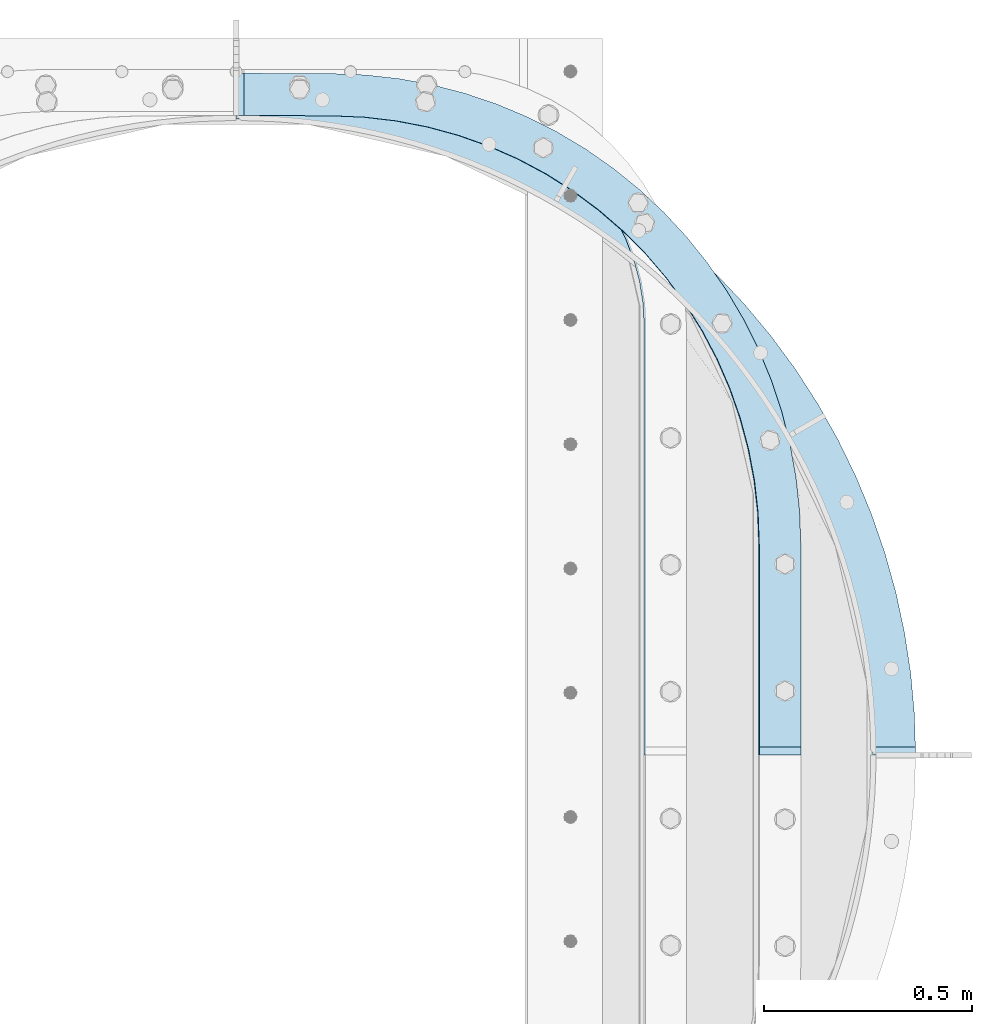
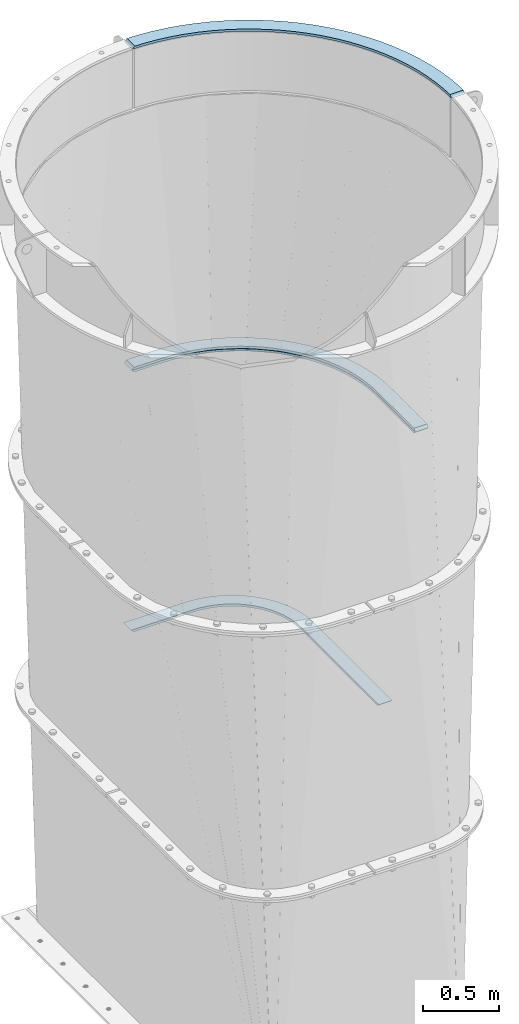
# One storey, part 14 of 15: 4 plates, 3 elements without a shape of their own.
"""IFC2X3 building model written with IfcOpenShell, lengths in millimetres."""

from ifc_helpers import new_model, si_unit, frame, origin_with_axes, place, context, subcontext, project, spatial, faceted_brep, material, type_object, element, aggregate, save


model = new_model("IFC2X3")

# Units and contexts
model_context = context("Model", 3, precision=1e-05, world=origin_with_axes())
body_context = subcontext(model_context, "Body", "Model", "MODEL_VIEW")
ifc_project = project(units=[si_unit("LENGTHUNIT", "METRE", prefix="MILLI"), si_unit("AREAUNIT", "SQUARE_METRE"), si_unit("VOLUMEUNIT", "CUBIC_METRE"), si_unit("MASSUNIT", "GRAM", prefix="KILO"), si_unit("TIMEUNIT", "SECOND"), si_unit("PLANEANGLEUNIT", "RADIAN"), si_unit("SOLIDANGLEUNIT", "STERADIAN"), si_unit("THERMODYNAMICTEMPERATUREUNIT", "DEGREE_CELSIUS"), si_unit("LUMINOUSINTENSITYUNIT", "LUMEN")], contexts=[model_context])

# Site, building, storey
site_placement = place(None, origin_with_axes())
site = spatial("IfcSite", under=ifc_project, at=site_placement, CompositionType="ELEMENT")
building_placement = place(site_placement, origin_with_axes())
building = spatial("IfcBuilding", under=site, at=building_placement, Name="Undefined", CompositionType="ELEMENT")
storey_placement = place(building_placement, origin_with_axes())
storey = spatial("IfcBuildingStorey", under=building, at=storey_placement, Name="Undefined", CompositionType="ELEMENT", Elevation=0.0)

# Assembly, plate
assembly_1_placement = place(storey_placement, origin_with_axes())
assembly_1 = element("IfcElementAssembly", 1, at=assembly_1_placement, inside=storey, Name="TRANSITION", AssemblyPlace="NOTDEFINED", PredefinedType="RIGID_FRAME")
ifc_material = material(Name="STEEL/A36")
plate_type_1 = type_object("IfcPlateType", PredefinedType="NOTDEFINED")
plate_1_placement = place(assembly_1_placement, frame((2235.57307813265, 1720.87907416661, 4192.06000019074), z_axis=(0.0, 1.0, 0.0), x_axis=(-1.0, 0.0, 0.0)))
plate_1 = element("IfcPlate", 2, at=plate_1_placement, type_object=plate_type_1, material=ifc_material, Name="PLATE", context=body_context, shape_type="Brep", body=[
    faceted_brep([(99.7946651598986, 9.52499949498906, 19.0499993169162), (99.7946014404297, -9.52499999999964, 0.0), (0.0, -9.52499999999964, 0.0), (8.52415855661093e-05, 9.52499999999964, 19.050446296787), (0.00226665040457874, -9.52499999999964, 506.568496906642), (2.86552112687696, -9.52499999999964, 586.965399212112), (2.86552112687696, 9.52499999999964, 586.965399212112), (0.00226665040457874, 9.52499999999964, 506.568496906642), (11.4400606208065, -9.52499999999964, 666.955007280796), (11.4400606208065, 9.52499999999964, 666.955007280796), (25.682448871113, -9.52499999999964, 746.132115736726), (25.682448871113, 9.52499999999964, 746.132115736726), (45.5205378522613, -9.52499999999964, 824.095635103739), (45.5205378522613, 9.52499999999964, 824.095635103739), (70.8538332563299, -9.52499999999964, 900.450623614542), (70.8538332563299, 9.52499999999964, 900.450623614542), (101.554003569561, -9.52499999999964, 974.810287877187), (101.554003569561, 9.52499999999964, 974.810287877187), (137.465530164548, -9.52499999999964, 1046.79794226412), (137.465530164548, 9.52499999999964, 1046.79794226412), (178.406495114871, -9.52499999999964, 1116.04891709806), (178.406495114871, 9.52499999999964, 1116.04891709806), (224.169502741328, -9.52499999999964, 1182.2124059684), (224.169502741328, 9.52499999999964, 1182.2124059684), (274.522730221457, -9.52499999999964, 1244.95324282008), (274.522730221457, 9.52499999999964, 1244.95324282008), (329.211101940261, -9.52499999999964, 1303.95359981273), (329.211101940261, 9.52499999999964, 1303.95359981273), (387.957581633183, -9.52499999999964, 1358.9145973492), (387.957581633183, 9.52499999999964, 1358.9145973492), (450.464575775707, -9.52499999999964, 1409.55781811744), (450.464575775707, 9.52499999999964, 1409.55781811744), (516.41544111038, -9.52499999999964, 1455.62671747614), (516.41544111038, 9.52499999999964, 1455.62671747614), (585.476088674554, -9.52499999999964, 1496.88792303938), (585.476088674554, 9.52499999999964, 1496.88792303938), (657.296676203268, -9.52499999999964, 1533.13241687699), (657.296676203268, 9.52499999999964, 1533.13241687699), (731.513380334047, -9.52499999999964, 1564.176594342), (731.513380334047, 9.52499999999964, 1564.176594342), (807.750239636084, -9.52499999999964, 1589.86319416129), (807.750239636084, 9.52499999999964, 1589.86319416129), (885.621059127542, -9.52499999999964, 1610.062095078), (885.621059127542, 9.52499999999964, 1610.062095078), (964.731366633227, -9.52499999999964, 1624.6709750101), (964.731366633227, 9.52499999999964, 1624.6709750101), (1044.68041107224, -9.52499999999964, 1633.61582938589), (1044.68041107224, 9.52499999999964, 1633.61582938589), (1125.06319255282, -9.52499999999964, 1636.85134603082), (1125.06319255282, 9.52499999999964, 1636.85134603082), (1356.09818592932, -9.52500019073523, 1637.92224121094), (1337.04797114386, 9.52499999999964, 1637.83394020392), (1356.09802246094, -9.52499999999964, 1536.322265625), (1337.04797114386, 9.52499999999964, 1536.23408996477), (1123.73482538487, -9.52499999999964, 1535.24674210153), (1123.73482538487, 9.52499999999964, 1535.24674210153), (1047.10030478318, -9.52499999999964, 1532.03247607219), (1047.10030478318, 9.52499999999964, 1532.03247607219), (970.918303938195, -9.52499999999964, 1523.11709603465), (970.918303938195, 9.52499999999964, 1523.11709603465), (895.612355762711, -9.52499999999964, 1508.55016693653), (895.612355762711, 9.52499999999964, 1508.55016693653), (821.601122765285, -9.52499999999964, 1488.41267344407), (821.601122765285, 9.52499999999964, 1488.41267344407), (749.2960695011, -9.52499999999964, 1462.8165697089), (749.2960695011, 9.52499999999964, 1462.8165697089), (679.099175039733, -9.52499999999964, 1431.90415696032), (679.099175039733, 9.52499999999964, 1431.90415696032), (611.400698167385, -9.52499999999964, 1395.84729238334), (611.400698167385, 9.52499999999964, 1395.84729238334), (546.57700774787, -9.52499999999964, 1354.84643368071), (546.57700774787, 9.52499999999964, 1354.84643368071), (484.988490304467, -9.52499999999964, 1309.12952463074), (484.988490304467, 9.52499999999964, 1309.12952463074), (426.977546455406, -9.52499999999964, 1258.95072783668), (426.977546455406, 9.52499999999964, 1258.95072783668), (372.866687341763, -9.52499999999964, 1204.58901171272), (372.866687341763, 9.52499999999964, 1204.58901171272), (322.956741630674, -9.52499999999964, 1146.34659956251), (322.956741630674, 9.52499999999964, 1146.34659956251), (277.525183061995, -9.52499999999964, 1084.54728937235), (277.525183061995, 9.52499999999964, 1084.54728937235), (236.824587836399, -9.52499999999964, 1019.5346536602), (236.824587836399, 9.52499999999964, 1019.5346536602), (201.081230421042, -9.52499999999964, 951.670129388405), (201.081230421042, 9.52499999999964, 951.670129388405), (170.493825579402, -9.52499999999964, 881.331008559293), (170.493825579402, 9.52499999999964, 881.331008559293), (145.232423618945, -9.52499999999964, 808.908340664835), (145.232423618945, 9.52499999999964, 808.908340664835), (125.437464998504, -9.52499999999964, 734.804758651724), (125.437464998504, 9.52499999999964, 734.804758651724), (111.218999551242, -9.52499999999964, 659.432240488378), (111.218999551242, 9.52499999999964, 659.432240488378), (102.656074663938, -9.52499999999964, 583.209818778404), (102.656074663938, 9.52499999999964, 583.209818778404), (99.7962958139181, -9.52499999999964, 506.561251153978), (99.7962958139181, 9.52499999999964, 506.561251153978)], [[[0, 1, 2, 3]], [[4, 5, 6, 7]], [[5, 8, 9, 6]], [[8, 10, 11, 9]], [[10, 12, 13, 11]], [[12, 14, 15, 13]], [[14, 16, 17, 15]], [[16, 18, 19, 17]], [[18, 20, 21, 19]], [[20, 22, 23, 21]], [[22, 24, 25, 23]], [[24, 26, 27, 25]], [[26, 28, 29, 27]], [[28, 30, 31, 29]], [[30, 32, 33, 31]], [[32, 34, 35, 33]], [[34, 36, 37, 35]], [[36, 38, 39, 37]], [[38, 40, 41, 39]], [[40, 42, 43, 41]], [[42, 44, 45, 43]], [[44, 46, 47, 45]], [[46, 48, 49, 47]], [[49, 48, 50, 51]], [[50, 52, 53, 51]], [[54, 55, 53, 52]], [[54, 56, 57, 55]], [[56, 58, 59, 57]], [[58, 60, 61, 59]], [[60, 62, 63, 61]], [[62, 64, 65, 63]], [[64, 66, 67, 65]], [[66, 68, 69, 67]], [[68, 70, 71, 69]], [[70, 72, 73, 71]], [[72, 74, 75, 73]], [[74, 76, 77, 75]], [[76, 78, 79, 77]], [[78, 80, 81, 79]], [[80, 82, 83, 81]], [[82, 84, 85, 83]], [[84, 86, 87, 85]], [[86, 88, 89, 87]], [[88, 90, 91, 89]], [[90, 92, 93, 91]], [[92, 94, 95, 93]], [[94, 96, 97, 95]], [[7, 6, 9, 11, 13, 15, 17, 19, 21, 23, 25, 27, 29, 31, 33, 35, 37, 39, 41, 43, 45, 47, 49, 51, 53, 55, 57, 59, 61, 63, 65, 67, 69, 71, 73, 75, 77, 79, 81, 83, 85, 87, 89, 91, 93, 95, 97, 0, 3]], [[4, 7, 3, 2]], [[1, 96, 94, 92, 90, 88, 86, 84, 82, 80, 78, 76, 74, 72, 70, 68, 66, 64, 62, 60, 58, 56, 54, 52, 50, 48, 46, 44, 42, 40, 38, 36, 34, 32, 30, 28, 26, 24, 22, 20, 18, 16, 14, 12, 10, 8, 5, 4, 2]], [[97, 96, 1, 0]]]),
])

assembly_2_placement = place(storey_placement, origin_with_axes())
assembly_2 = element("IfcElementAssembly", 3, at=assembly_2_placement, inside=storey, Name="TRANSITION", AssemblyPlace="NOTDEFINED", PredefinedType="RIGID_FRAME")
plate_2_placement = place(assembly_2_placement, frame((2235.57307813265, 1720.87907416661, 4173.01), z_axis=(0.0, 1.0, 0.0), x_axis=(-1.0, 0.0, 0.0)))
plate_2 = element("IfcPlate", 4, at=plate_2_placement, type_object=plate_type_1, material=ifc_material, Name="PLATE", context=body_context, shape_type="Brep", body=[
    faceted_brep([(101.600061997572, -9.52500095346932, 18.9913965695221), (8.49794006967386e-05, -9.52499999999964, 18.99185122937), (0.0, 9.52499999999964, 0.0), (101.599998474121, 9.52499999999964, 0.0), (0.00226665040457874, -9.52499999999964, 506.568496906642), (2.86552112687696, -9.52499999999964, 586.965399212112), (2.86552112687696, 9.52499999999964, 586.965399212112), (0.00226665040457874, 9.52499999999964, 506.568496906642), (11.4400606208065, -9.52499999999964, 666.955007280796), (11.4400606208065, 9.52499999999964, 666.955007280796), (25.682448871113, -9.52499999999964, 746.132115736726), (25.682448871113, 9.52499999999964, 746.132115736726), (45.5205378522613, -9.52499999999964, 824.095635103739), (45.5205378522613, 9.52499999999964, 824.095635103739), (70.8538332563299, -9.52499999999964, 900.450623614542), (70.8538332563299, 9.52499999999964, 900.450623614542), (101.554003569561, -9.52499999999964, 974.810287877187), (101.554003569561, 9.52499999999964, 974.810287877187), (137.465530164548, -9.52499999999964, 1046.79794226412), (137.465530164548, 9.52499999999964, 1046.79794226412), (178.406495114871, -9.52499999999964, 1116.04891709806), (178.406495114871, 9.52499999999964, 1116.04891709806), (224.169502741328, -9.52499999999964, 1182.2124059684), (224.169502741328, 9.52499999999964, 1182.2124059684), (274.522730221457, -9.52499999999964, 1244.95324282008), (274.522730221457, 9.52499999999964, 1244.95324282008), (329.211101940261, -9.52499999999964, 1303.95359981273), (329.211101940261, 9.52499999999964, 1303.95359981273), (387.957581633183, -9.52499999999964, 1358.9145973492), (387.957581633183, 9.52499999999964, 1358.9145973492), (450.464575775707, -9.52499999999964, 1409.55781811744), (450.464575775707, 9.52499999999964, 1409.55781811744), (516.41544111038, -9.52499999999964, 1455.62671747614), (516.41544111038, 9.52499999999964, 1455.62671747614), (585.476088674554, -9.52499999999964, 1496.88792303938), (585.476088674554, 9.52499999999964, 1496.88792303938), (657.296676203268, -9.52499999999964, 1533.13241687699), (657.296676203268, 9.52499999999964, 1533.13241687699), (731.513380334047, -9.52499999999964, 1564.176594342), (731.513380334047, 9.52499999999964, 1564.176594342), (807.750239636084, -9.52499999999964, 1589.86319416129), (807.750239636084, 9.52499999999964, 1589.86319416129), (885.621059127542, -9.52499999999964, 1610.062095078), (885.621059127542, 9.52499999999964, 1610.062095078), (964.731366633227, -9.52499999999964, 1624.6709750101), (964.731366633227, 9.52499999999964, 1624.6709750101), (1044.68041107224, -9.52499999999964, 1633.61582938589), (1044.68041107224, 9.52499999999964, 1633.61582938589), (1125.06319255282, -9.52499999999964, 1636.85134603082), (1125.06319255282, 9.52499999999964, 1636.85134603082), (1337.04797114109, -9.52499999999964, 1637.83394020391), (1356.09818592933, 9.52499847412037, 1637.92224121094), (1337.04797114109, -9.52499999999964, 1536.23396306721), (1356.09802246094, 9.52499999999964, 1536.322265625), (1125.53337021302, -9.52499999999964, 1535.25353104851), (1125.53337021302, 9.52499999999964, 1535.25353104851), (1048.89919630054, -9.52499999999964, 1532.03878036735), (1048.89919630054, 9.52499999999964, 1532.03878036735), (972.717574464455, -9.52499999999964, 1523.1229670218), (972.717574464455, 9.52499999999964, 1523.1229670218), (897.41203190946, -9.52499999999964, 1508.55565794681), (897.41203190946, 9.52499999999964, 1508.55565794681), (823.401225329481, -9.52499999999964, 1488.41783923252), (823.401225329481, 9.52499999999964, 1488.41783923252), (751.096613410651, -9.52499999999964, 1462.82146588676), (751.096613410651, 9.52499999999964, 1462.82146588676), (680.900169351152, -9.52499999999964, 1431.90883942782), (680.900169351152, 9.52499999999964, 1431.90883942782), (613.202146115094, -9.52499999999964, 1395.85181676761), (613.202146115094, 9.52499999999964, 1395.85181676761), (548.378906844311, -9.52499999999964, 1354.8508547834), (548.378906844311, 9.52499999999964, 1354.8508547834), (486.790832489823, -9.52499999999964, 1309.13389588963), (486.790832489823, 9.52499999999964, 1309.13389588963), (428.780318295328, -9.52499999999964, 1258.95510080566), (428.780318295328, 9.52499999999964, 1258.95510080566), (374.669870271166, -9.52499999999964, 1204.59343556431), (374.669870271166, 9.52499999999964, 1204.59343556431), (324.7603122413, -9.52499999999964, 1146.35112061673), (324.7603122413, 9.52499999999964, 1146.35112061673), (279.32911343112, -9.52499999999964, 1084.55195065581), (279.32911343112, 9.52499999999964, 1084.55195065581), (238.628845893756, -9.52499999999964, 1019.53949449874), (238.628845893756, 9.52499999999964, 1019.53949449874), (202.885780350741, -9.52499999999964, 951.67518503657), (202.885780350741, 9.52499999999964, 951.67518503657), (172.298628253365, -9.52499999999964, 881.336309869553), (172.298628253365, 9.52499999999964, 881.336309869553), (147.037437058154, -9.52499999999964, 808.913913799081), (147.037437058154, 9.52499999999964, 808.913913799081), (127.242644858133, -9.52499999999964, 734.810624837339), (127.242644858133, 9.52499999999964, 734.810624837339), (113.024299625579, -9.52499999999964, 659.438415820769), (113.024299625579, 9.52499999999964, 659.438415820769), (104.461447406857, -9.52499999999964, 583.21631407154), (104.461447406857, 9.52499999999964, 583.21631407154), (101.601692870424, -9.52499999999964, 506.568071840215), (101.601692870424, 9.52499999999964, 506.568071840215)], [[[0, 1, 2, 3]], [[4, 5, 6, 7]], [[5, 8, 9, 6]], [[8, 10, 11, 9]], [[10, 12, 13, 11]], [[12, 14, 15, 13]], [[14, 16, 17, 15]], [[16, 18, 19, 17]], [[18, 20, 21, 19]], [[20, 22, 23, 21]], [[22, 24, 25, 23]], [[24, 26, 27, 25]], [[26, 28, 29, 27]], [[28, 30, 31, 29]], [[30, 32, 33, 31]], [[32, 34, 35, 33]], [[34, 36, 37, 35]], [[36, 38, 39, 37]], [[38, 40, 41, 39]], [[40, 42, 43, 41]], [[42, 44, 45, 43]], [[44, 46, 47, 45]], [[46, 48, 49, 47]], [[49, 48, 50, 51]], [[51, 50, 52, 53]], [[54, 55, 53, 52]], [[54, 56, 57, 55]], [[56, 58, 59, 57]], [[58, 60, 61, 59]], [[60, 62, 63, 61]], [[62, 64, 65, 63]], [[64, 66, 67, 65]], [[66, 68, 69, 67]], [[68, 70, 71, 69]], [[70, 72, 73, 71]], [[72, 74, 75, 73]], [[74, 76, 77, 75]], [[76, 78, 79, 77]], [[78, 80, 81, 79]], [[80, 82, 83, 81]], [[82, 84, 85, 83]], [[84, 86, 87, 85]], [[86, 88, 89, 87]], [[88, 90, 91, 89]], [[90, 92, 93, 91]], [[92, 94, 95, 93]], [[94, 96, 97, 95]], [[97, 96, 0, 3]], [[7, 6, 9, 11, 13, 15, 17, 19, 21, 23, 25, 27, 29, 31, 33, 35, 37, 39, 41, 43, 45, 47, 49, 51, 53, 55, 57, 59, 61, 63, 65, 67, 69, 71, 73, 75, 77, 79, 81, 83, 85, 87, 89, 91, 93, 95, 97, 3, 2]], [[4, 7, 2, 1]], [[96, 94, 92, 90, 88, 86, 84, 82, 80, 78, 76, 74, 72, 70, 68, 66, 64, 62, 60, 58, 56, 54, 52, 50, 48, 46, 44, 42, 40, 38, 36, 34, 32, 30, 28, 26, 24, 22, 20, 18, 16, 14, 12, 10, 8, 5, 4, 1, 0]]]),
])
aggregate(assembly_2, [plate_2])

assembly_3_placement = place(storey_placement, origin_with_axes())
assembly_3 = element("IfcElementAssembly", 5, at=assembly_3_placement, inside=storey, Name="TRANSITION", AssemblyPlace="NOTDEFINED", PredefinedType="RIGID_FRAME")
plate_type_2 = type_object("IfcPlateType", PredefinedType="NOTDEFINED")
plate_3_placement = place(assembly_3_placement, frame((1960.91443882889, 3367.72732659698, 2091.265), z_axis=(-1.0, 0.0, 0.0), x_axis=(0.0, -1.0, 0.0)))
plate_3 = element("IfcPlate", 6, at=plate_3_placement, type_object=plate_type_2, material=ifc_material, Name="PLATE", context=body_context, shape_type="Brep", body=[
    faceted_brep([(101.599998474121, 9.52499923706046, 1081.43954662556), (-1.52587881530053e-06, 9.52500000000009, 1081.43933105469), (-1.49899983625801e-06, -9.52500000000009, 1062.38933163032), (101.599998474121, -9.52500000000009, 1062.38933173196), (2.96596717177431, -9.52500000000009, 555.576352917761), (-5.43179524470361e-07, -9.52500000000009, 615.950011663852), (-5.43179524470361e-07, 9.52500000000009, 615.950011663852), (2.96596717177431, 9.52500000000009, 555.576352917761), (11.8353063197283, -9.52500000000009, 495.784125513574), (11.8353063197283, 9.52500000000009, 495.784125513574), (26.5226003163094, -9.52500000000009, 437.149161286301), (26.5226003163094, 9.52500000000009, 437.149161286301), (46.8864024915977, -9.52500000000009, 380.236146993951), (46.8864024915977, 9.52500000000009, 380.236146993951), (72.7305982988784, -9.52500000000009, 325.593186075362), (72.7305982988784, 9.52500000000009, 325.593186075362), (103.806294004932, -9.52500000000009, 273.746520114471), (103.806294004932, 9.52500000000009, 273.746520114471), (139.814213672743, -9.52500000000009, 225.195460846191), (139.814213672743, 9.52500000000009, 225.195460846191), (180.407581352366, -9.52500000000009, 180.40758151146), (180.407581352366, 9.52500000000009, 180.40758151146), (225.195460722895, -9.52500000000009, 139.814213871333), (225.195460722895, 9.52500000000009, 139.814213871333), (273.746520022929, -9.52500000000009, 103.806294246338), (273.746520022929, 9.52500000000009, 103.806294246338), (325.593186011224, -9.52500000000009, 72.7305985860049), (325.593186011224, 9.52500000000009, 72.7305985860049), (380.236146952604, -9.52500000000009, 46.8864028269114), (380.236146952604, 9.52500000000009, 46.8864028269114), (437.149161262912, -9.52500000000009, 26.5226007018123), (437.149161262912, 9.52500000000009, 26.5226007018123), (495.784125503137, -9.52500000000009, 11.8353067569387), (495.784125503137, 9.52500000000009, 11.8353067569387), (555.576352915146, -9.52500000000009, 2.96596766171297), (555.576352915146, 9.52500000000009, 2.96596766171297), (615.950011663852, -9.52500000000009, 0.0), (615.950011663852, 9.52500000000009, 0.0), (1646.87731933594, 9.52500000000009, 0.0), (1627.82733485471, -9.52500000000009, 0.0), (1646.87733404866, 9.52499923706046, 101.599998473973), (1627.82732009888, -9.52500000000009, 101.599998474121), (615.949974060059, 9.52500000000009, 101.599998474121), (615.949974060059, -9.52500000000009, 101.599998474121), (562.185761530305, -9.52500000000009, 104.417661457707), (562.185761530305, 9.52500000000009, 104.417661457707), (509.010600963913, -9.52500000000009, 112.839779503182), (509.010600963913, 9.52500000000009, 112.839779503182), (457.007090547665, -9.52500000000009, 126.7740781228), (457.007090547665, 9.52500000000009, 126.7740781228), (406.744991624115, -9.52500000000009, 146.067890224943), (406.744991624115, 9.52500000000009, 146.067890224943), (358.77498626709, -9.52500000000009, 170.509828766731), (358.77498626709, 9.52500000000009, 170.509828766731), (313.622643893651, -9.52500000000009, 199.832102754696), (313.622643893651, 9.52500000000009, 199.832102754696), (271.782663015576, -9.52500000000009, 233.713451218945), (271.782663015576, 9.52500000000009, 233.713451218945), (233.713451218945, -9.52500000000009, 271.782663015577), (233.713451218945, 9.52500000000009, 271.782663015577), (199.832102754696, -9.52500000000009, 313.622643893651), (199.832102754696, 9.52500000000009, 313.622643893651), (170.509828766731, -9.52500000000009, 358.77498626709), (170.509828766731, 9.52500000000009, 358.77498626709), (146.067890224943, -9.52500000000009, 406.744991624115), (146.067890224943, 9.52500000000009, 406.744991624115), (126.7740781228, -9.52500000000009, 457.007090547665), (126.7740781228, 9.52500000000009, 457.007090547665), (112.839779503182, -9.52500000000009, 509.010600963913), (112.839779503182, 9.52500000000009, 509.010600963913), (104.417661457707, -9.52500000000009, 562.185761530306), (104.417661457707, 9.52500000000009, 562.185761530306), (101.599998474121, -9.52500000000009, 615.949974060059), (101.599998474121, 9.52500000000009, 615.949974060059)], [[[0, 1, 2, 3]], [[4, 5, 6, 7]], [[8, 4, 7, 9]], [[10, 8, 9, 11]], [[12, 10, 11, 13]], [[14, 12, 13, 15]], [[16, 14, 15, 17]], [[18, 16, 17, 19]], [[20, 18, 19, 21]], [[22, 20, 21, 23]], [[24, 22, 23, 25]], [[26, 24, 25, 27]], [[28, 26, 27, 29]], [[30, 28, 29, 31]], [[32, 30, 31, 33]], [[34, 32, 33, 35]], [[36, 34, 35, 37]], [[36, 37, 38, 39]], [[40, 41, 39, 38]], [[42, 43, 41, 40]], [[44, 43, 42, 45]], [[46, 44, 45, 47]], [[48, 46, 47, 49]], [[50, 48, 49, 51]], [[52, 50, 51, 53]], [[54, 52, 53, 55]], [[56, 54, 55, 57]], [[58, 56, 57, 59]], [[60, 58, 59, 61]], [[62, 60, 61, 63]], [[64, 62, 63, 65]], [[66, 64, 65, 67]], [[68, 66, 67, 69]], [[70, 68, 69, 71]], [[72, 70, 71, 73]], [[72, 73, 0, 3]], [[5, 4, 8, 10, 12, 14, 16, 18, 20, 22, 24, 26, 28, 30, 32, 34, 36, 39, 41, 43, 44, 46, 48, 50, 52, 54, 56, 58, 60, 62, 64, 66, 68, 70, 72, 3, 2]], [[6, 5, 2, 1]], [[73, 71, 69, 67, 65, 63, 61, 59, 57, 55, 53, 51, 49, 47, 45, 42, 40, 38, 37, 35, 33, 31, 29, 27, 25, 23, 21, 19, 17, 15, 13, 11, 9, 7, 6, 1, 0]]]),
])
aggregate(assembly_3, [plate_3])

# Plate
plate_type_3 = type_object("IfcPlateType", PredefinedType="NOTDEFINED")
plate_4_placement = place(assembly_1_placement, frame((879.475000000271, 3352.79995117187, 6762.755), z_axis=(1.0, 0.0, 0.0), x_axis=(0.0, -1.0, 0.0)))
plate_4 = element("IfcPlate", 7, at=plate_4_placement, type_object=plate_type_3, material=ifc_material, Name="PLATE", context=body_context, shape_type="Brep", body=[
    faceted_brep([(103.1875, 9.52499999999964, 0.0), (103.76313049706, -9.52499999999964, 19.05), (0.57563035489018, -9.52499999999964, 19.05), (0.0, 9.52499999999964, 0.0), (1631.94995117188, 9.52499999999964, 1631.94995117188), (1612.89995117188, -9.52499999999964, 1631.37432081696), (1612.89995117188, -9.52499999999964, 1528.18682067481), (1631.94995117188, 9.52499999999964, 1528.76245117188), (2.97740452312382, -9.52499999999964, 98.5346858164392), (2.97740452312382, 9.52499999999964, 98.5346858164392), (11.8987531805783, -9.52499999999964, 196.709829232645), (11.8987531805783, 9.52499999999964, 196.709829232645), (26.7314929387344, -9.52499999999964, 294.167199800127), (26.7314929387344, 9.52499999999964, 294.167199800127), (47.4215007392556, -9.52499999999964, 390.55118614576), (47.4215007392556, 9.52499999999964, 390.55118614576), (73.8932809881087, -9.52499999999964, 485.510093559006), (73.8932809881087, 9.52499999999964, 485.510093559006), (106.050241030797, -9.52499999999964, 578.697427287759), (106.050241030797, 9.52499999999964, 578.697427287759), (143.77504360848, -9.52499999999964, 669.77315686011), (143.77504360848, 9.52499999999964, 669.77315686011), (186.930035008899, -9.52499999999964, 758.404956818652), (186.930035008899, 9.52499999999964, 758.404956818652), (235.357747349844, -9.52499999999964, 844.269419340023), (235.357747349844, 9.52499999999964, 844.269419340023), (288.881473162371, -9.52499999999964, 927.053234314973), (288.881473162371, 9.52499999999964, 927.053234314973), (347.30591017719, -9.52499999999964, 1006.45433258296), (347.30591017719, 9.52499999999964, 1006.45433258296), (410.417873961457, -9.52499999999964, 1082.18298814976), (410.417873961457, 9.52499999999964, 1082.18298814976), (477.987075805645, -9.52499999999964, 1153.96287536617), (477.987075805645, 9.52499999999964, 1153.96287536617), (549.766963022063, -9.52499999999964, 1221.53207721036), (549.766963022063, 9.52499999999964, 1221.53207721036), (625.495618588867, -9.52499999999964, 1284.64404099462), (625.495618588867, 9.52499999999964, 1284.64404099462), (704.896716856861, -9.52499999999964, 1343.06847800943), (704.896716856861, 9.52499999999964, 1343.06847800943), (787.680531831816, -9.52499999999964, 1396.59220382195), (787.680531831816, 9.52499999999964, 1396.59220382195), (873.544994353191, -9.52499999999964, 1445.01991616288), (873.544994353191, 9.52499999999964, 1445.01991616288), (962.176794311736, -9.52499999999964, 1488.1749075633), (962.176794311736, 9.52499999999964, 1488.1749075633), (1053.25252388409, -9.52499999999964, 1525.89971014097), (1053.25252388409, 9.52499999999964, 1525.89971014097), (1146.43985761284, -9.52499999999964, 1558.05667018365), (1146.43985761284, 9.52499999999964, 1558.05667018365), (1241.39876502609, -9.52499999999964, 1584.52845043249), (1241.39876502609, 9.52499999999964, 1584.52845043249), (1337.78275137173, -9.52499999999964, 1605.21845823301), (1337.78275137173, 9.52499999999964, 1605.21845823301), (1435.24012193921, -9.52499999999964, 1620.05119799115), (1435.24012193921, 9.52499999999964, 1620.05119799115), (1533.41526535541, -9.52499999999964, 1628.9725466486), (1533.41526535541, 9.52499999999964, 1628.9725466486), (1539.64557176765, -9.52499999999964, 1525.97330598564), (1539.64557176765, 9.52499999999964, 1525.97330598564), (1447.67800108681, -9.52499999999964, 1517.61604978902), (1447.67800108681, 9.52499999999964, 1517.61604978902), (1356.3828188116, -9.52499999999964, 1503.7211773028), (1356.3828188116, 9.52499999999964, 1503.7211773028), (1266.09315115196, -9.52499999999964, 1484.33938940837), (1266.09315115196, 9.52499999999964, 1484.33938940837), (1177.13845530415, -9.52499999999964, 1459.54140814586), (1177.13845530415, 9.52499999999964, 1459.54140814586), (1089.84331729719, -9.52499999999964, 1429.41771865703), (1089.84331729719, 9.52499999999964, 1429.41771865703), (1004.5262676137, -9.52499999999964, 1394.07823901488), (1004.5262676137, 9.52499999999964, 1394.07823901488), (921.498618906718, -9.52499999999964, 1353.65191914449), (921.498618906718, 9.52499999999964, 1353.65191914449), (841.063330053642, -9.52499999999964, 1308.28627029875), (841.063330053642, 9.52499999999964, 1308.28627029875), (763.513900692163, -9.52499999999964, 1258.1468268058), (763.513900692163, 9.52499999999964, 1258.1468268058), (689.133300271954, -9.52499999999964, 1203.41654205227), (689.133300271954, 9.52499999999964, 1203.41654205227), (618.192935529858, -9.52499999999964, 1144.29512090619), (618.192935529858, 9.52499999999964, 1144.29512090619), (550.95166015617, -9.52499999999964, 1080.99829101564), (550.95166015617, 9.52499999999964, 1080.99829101564), (487.654830265622, -9.52499999999964, 1013.75701564195), (487.654830265622, 9.52499999999964, 1013.75701564195), (428.533409119548, -9.52499999999964, 942.816650899848), (428.533409119548, 9.52499999999964, 942.816650899848), (373.80312436602, -9.52499999999964, 868.436050479634), (373.80312436602, 9.52499999999964, 868.436050479634), (323.663680873077, -9.52499999999964, 790.88662111815), (323.663680873077, 9.52499999999964, 790.88662111815), (278.298032027336, -9.52499999999964, 710.451332265068), (278.298032027336, 9.52499999999964, 710.451332265068), (237.871712156949, -9.52499999999964, 627.423683558081), (237.871712156949, 9.52499999999964, 627.423683558081), (202.532232514805, -9.52499999999964, 542.106633874585), (202.532232514805, 9.52499999999964, 542.106633874585), (172.408543025982, -9.52499999999964, 454.811495867622), (172.408543025982, 9.52499999999964, 454.811495867622), (147.610561763468, -9.52499999999964, 365.856800019807), (147.610561763468, 9.52499999999964, 365.856800019807), (128.228773869042, -9.52499999999964, 275.567132360162), (128.228773869042, 9.52499999999964, 275.567132360162), (114.333901382821, -9.52499999999964, 184.271950084946), (114.333901382821, 9.52499999999964, 184.271950084946), (105.976645186203, -9.52499999999964, 92.3043794040959), (105.976645186203, 9.52499999999964, 92.3043794040959)], [[[0, 1, 2, 3]], [[4, 5, 6, 7]], [[8, 9, 3, 2]], [[8, 10, 11, 9]], [[10, 12, 13, 11]], [[12, 14, 15, 13]], [[14, 16, 17, 15]], [[16, 18, 19, 17]], [[18, 20, 21, 19]], [[20, 22, 23, 21]], [[22, 24, 25, 23]], [[24, 26, 27, 25]], [[26, 28, 29, 27]], [[28, 30, 31, 29]], [[30, 32, 33, 31]], [[32, 34, 35, 33]], [[34, 36, 37, 35]], [[36, 38, 39, 37]], [[38, 40, 41, 39]], [[40, 42, 43, 41]], [[42, 44, 45, 43]], [[44, 46, 47, 45]], [[46, 48, 49, 47]], [[48, 50, 51, 49]], [[50, 52, 53, 51]], [[52, 54, 55, 53]], [[54, 56, 57, 55]], [[57, 56, 5, 4]], [[58, 59, 7, 6]], [[58, 60, 61, 59]], [[60, 62, 63, 61]], [[62, 64, 65, 63]], [[64, 66, 67, 65]], [[66, 68, 69, 67]], [[68, 70, 71, 69]], [[70, 72, 73, 71]], [[72, 74, 75, 73]], [[74, 76, 77, 75]], [[76, 78, 79, 77]], [[78, 80, 81, 79]], [[80, 82, 83, 81]], [[82, 84, 85, 83]], [[84, 86, 87, 85]], [[86, 88, 89, 87]], [[88, 90, 91, 89]], [[90, 92, 93, 91]], [[92, 94, 95, 93]], [[94, 96, 97, 95]], [[96, 98, 99, 97]], [[98, 100, 101, 99]], [[100, 102, 103, 101]], [[102, 104, 105, 103]], [[104, 106, 107, 105]], [[107, 106, 1, 0]], [[11, 13, 15, 17, 19, 21, 23, 25, 27, 29, 31, 33, 35, 37, 39, 41, 43, 45, 47, 49, 51, 53, 55, 57, 4, 7, 59, 61, 63, 65, 67, 69, 71, 73, 75, 77, 79, 81, 83, 85, 87, 89, 91, 93, 95, 97, 99, 101, 103, 105, 107, 0, 3, 9]], [[56, 54, 52, 50, 48, 46, 44, 42, 40, 38, 36, 34, 32, 30, 28, 26, 24, 22, 20, 18, 16, 14, 12, 10, 8, 2, 1, 106, 104, 102, 100, 98, 96, 94, 92, 90, 88, 86, 84, 82, 80, 78, 76, 74, 72, 70, 68, 66, 64, 62, 60, 58, 6, 5]]]),
])

aggregate(assembly_1, [plate_1, plate_4])

save(model, "model.ifc")
